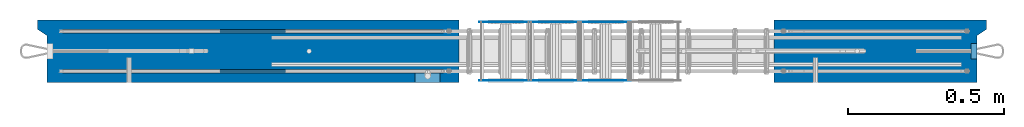
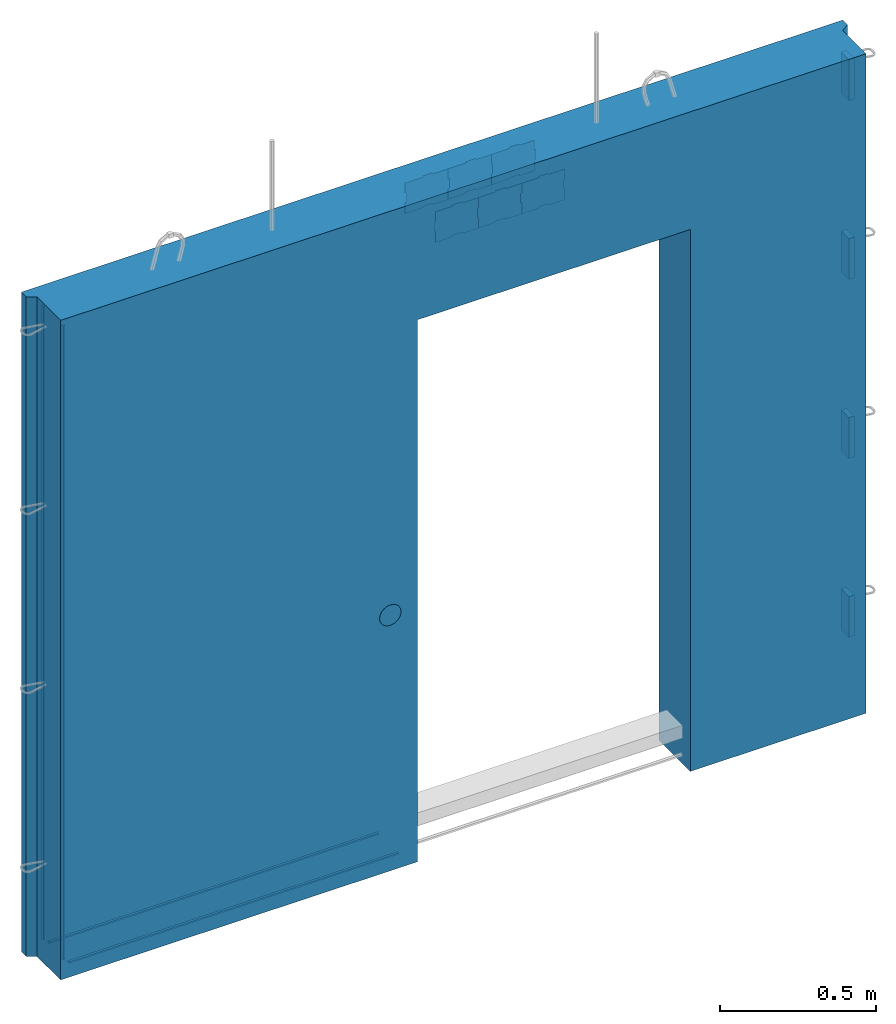
# One storey, part 6 of 11: 11 plates, 2 reinforcing bars, 1 wall.
"""IFC2X3 building model written with IfcOpenShell, lengths in millimetres."""

from ifc_helpers import new_model, si_unit, frame, origin_with_axes, place, context, subcontext, project, spatial, faceted_brep, source, transform, mapped, material, type_object, element, save


model = new_model("IFC2X3")

# Units and contexts
model_context = context("Model", 3, precision=1e-05, world=origin_with_axes())
body_context = subcontext(model_context, "Body", "Model", "MODEL_VIEW")
ifc_project = project(units=[si_unit("LENGTHUNIT", "METRE", prefix="MILLI"), si_unit("AREAUNIT", "SQUARE_METRE"), si_unit("VOLUMEUNIT", "CUBIC_METRE"), si_unit("MASSUNIT", "GRAM", prefix="KILO"), si_unit("TIMEUNIT", "SECOND"), si_unit("PLANEANGLEUNIT", "RADIAN"), si_unit("SOLIDANGLEUNIT", "STERADIAN"), si_unit("THERMODYNAMICTEMPERATUREUNIT", "DEGREE_CELSIUS"), si_unit("LUMINOUSINTENSITYUNIT", "LUMEN")], contexts=[model_context])

# Site, building, storey
site_placement = place(None, origin_with_axes())
site = spatial("IfcSite", under=ifc_project, at=site_placement, CompositionType="ELEMENT")
building_placement = place(site_placement, origin_with_axes())
building = spatial("IfcBuilding", under=site, at=building_placement, Name="Undefined", CompositionType="ELEMENT")
storey_placement = place(building_placement, origin_with_axes())
storey = spatial("IfcBuildingStorey", under=building, at=storey_placement, Name="Undefined", CompositionType="ELEMENT", Elevation=0.0)

# Plates
ifc_material_1 = material(Name="STEEL/Steel_Undefined")
plate_type_1 = type_object("IfcPlateType", PredefinedType="NOTDEFINED")
for number, where, z_axis, x_axis, name in (
    (1, (2990.01526628549, -74.9999984225414, 212.500000041022), (1.0, 0.0, 0.0), (0.0, -1.0, 0.0), "VL80"),
    (2, (2990.01526378904, -75.0000004196463, 912.500000041034), (1.0, 0.0, 0.0), (0.0, -1.0, 0.0), "VL80"),
    (3, (2990.01526378897, -75.0000004196424, 1612.50000004103), (1.0, 0.0, 0.0), (0.0, -1.0, 0.0), "VL80"),
    (4, (2990.01526378889, -75.0000004196453, 2312.50000004103), (1.0, 0.0, 0.0), (0.0, -1.0, 0.0), "VL80"),
):
    element("IfcPlate", number, at=place(storey_placement, frame(where, z_axis=z_axis, x_axis=x_axis)), inside=storey, type_object=plate_type_1, material=ifc_material_1, Name=name, context=body_context, shape_type="Brep", body=[
        faceted_brep([(-1.4210854715202e-14, -80.0, -7.105427357601e-15), (-1.4210854715202e-14, -80.0, 20.0), (-1.4210854715202e-14, 80.0, 20.0), (-1.4210854715202e-14, 80.0, -7.105427357601e-15), (50.0, -80.0, 20.0), (50.0, 80.0, 20.0), (50.0, -80.0, -7.105427357601e-15), (50.0, 80.0, -7.105427357601e-15)], [[[0, 1, 2, 3]], [[1, 4, 5, 2]], [[4, 6, 7, 5]], [[6, 0, 3, 7]], [[5, 7, 3, 2]], [[6, 4, 1, 0]]]),
    ])
plate_type_2 = type_object("IfcPlateType", PredefinedType="NOTDEFINED")
plate_1_placement = place(storey_placement, frame((1734.98457749309, -6.08317012009302, 2270.0138184004), z_axis=(0.0, 0.0, 1.0), x_axis=(-1.0, 0.0, 0.0)))
element("IfcPlate", 5, at=plate_1_placement, inside=storey, type_object=plate_type_2, material=ifc_material_1, context=body_context, shape_type="Brep", body=[
    faceted_brep([(0.0, -1.0, 0.0), (0.0, -1.0, 43.0), (0.0, 1.0, 43.0), (0.0, 1.0, 0.0), (-5.0, -1.0, 44.0), (-5.0, 1.0, 44.0), (-5.0, -1.0, 81.0), (-5.0, 1.0, 81.0), (0.0, -1.0, 82.0), (0.0, 1.0, 82.0), (0.0, -1.0, 120.0), (0.0, 1.0, 120.0), (55.5, -1.0, 120.0), (55.5, 1.0, 120.0), (56.5, -1.0, 125.0), (56.5, 1.0, 125.0), (93.5, -1.0, 125.0), (93.5, 1.0, 125.0), (94.5, -1.0, 120.0), (94.5, 1.0, 120.0), (160.0, -1.0, 120.0), (160.0, 1.0, 120.0), (160.0, -1.0, 82.0), (160.0, 1.0, 82.0), (155.0, -1.0, 81.0), (155.0, 1.0, 81.0), (155.0, -1.0, 44.0), (155.0, 1.0, 44.0), (160.0, -1.0, 43.0), (160.0, 1.0, 43.0), (160.0, -1.0, -2.72848410531878e-12), (160.0, 1.0, -2.72848410531878e-12), (94.5, -1.0, 0.0), (94.5, 1.0, 0.0), (93.5, -1.0, 5.0), (93.5, 1.0, 5.0), (56.5, -1.0, 5.0), (56.5, 1.0, 5.0), (55.5, -1.0, 0.0), (55.5, 1.0, 0.0)], [[[0, 1, 2, 3]], [[1, 4, 5, 2]], [[4, 6, 7, 5]], [[6, 8, 9, 7]], [[8, 10, 11, 9]], [[10, 12, 13, 11]], [[12, 14, 15, 13]], [[14, 16, 17, 15]], [[16, 18, 19, 17]], [[18, 20, 21, 19]], [[20, 22, 23, 21]], [[22, 24, 25, 23]], [[24, 26, 27, 25]], [[26, 28, 29, 27]], [[28, 30, 31, 29]], [[30, 32, 33, 31]], [[32, 34, 35, 33]], [[34, 36, 37, 35]], [[36, 38, 39, 37]], [[38, 0, 3, 39]], [[5, 7, 9, 11, 13, 15, 17, 19, 21, 23, 25, 27, 29, 31, 33, 35, 37, 39, 3, 2]], [[38, 36, 34, 32, 30, 28, 26, 24, 22, 20, 18, 16, 14, 12, 10, 8, 6, 4, 1, 0]]]),
])
plate_2_placement = place(storey_placement, frame((1739.98457749309, -194.083170120093, 2270.0138184004), z_axis=(0.0, 0.0, 1.0), x_axis=(-1.0, 0.0, 0.0)))
element("IfcPlate", 6, at=plate_2_placement, inside=storey, type_object=plate_type_2, material=ifc_material_1, context=body_context, shape_type="Brep", body=[
    faceted_brep([(0.0, -1.0, 0.0), (0.0, -1.0, 43.0), (0.0, 1.0, 43.0), (0.0, 1.0, 0.0), (5.0, -1.0, 44.0), (5.0, 1.0, 44.0), (5.0, -1.0, 81.0), (5.0, 1.0, 81.0), (0.0, -1.0, 82.0), (0.0, 1.0, 82.0), (0.0, -1.0, 120.0), (0.0, 1.0, 120.0), (60.5, -1.0, 120.0), (60.5, 1.0, 120.0), (61.5, -1.0, 125.0), (61.5, 1.0, 125.0), (98.5, -1.0, 125.0), (98.5, 1.0, 125.0), (99.5, -1.0, 120.0), (99.5, 1.0, 120.0), (160.0, -1.0, 120.0), (160.0, 1.0, 120.0), (160.0, -1.0, 82.0), (160.0, 1.0, 82.0), (165.0, -1.0, 81.0), (165.0, 1.0, 81.0), (165.0, -1.0, 44.0), (165.0, 1.0, 44.0), (160.0, -1.0, 43.0), (160.0, 1.0, 43.0), (160.0, -1.0, -2.72848410531878e-12), (160.0, 1.0, -2.72848410531878e-12), (99.5, -1.0, 0.0), (99.5, 1.0, 0.0), (98.5, -1.0, 5.0), (98.5, 1.0, 5.0), (61.5, -1.0, 5.0), (61.5, 1.0, 5.0), (60.5, -1.0, 0.0), (60.5, 1.0, 0.0)], [[[0, 1, 2, 3]], [[1, 4, 5, 2]], [[4, 6, 7, 5]], [[6, 8, 9, 7]], [[8, 10, 11, 9]], [[10, 12, 13, 11]], [[12, 14, 15, 13]], [[14, 16, 17, 15]], [[16, 18, 19, 17]], [[18, 20, 21, 19]], [[20, 22, 23, 21]], [[22, 24, 25, 23]], [[24, 26, 27, 25]], [[26, 28, 29, 27]], [[28, 30, 31, 29]], [[30, 32, 33, 31]], [[32, 34, 35, 33]], [[34, 36, 37, 35]], [[36, 38, 39, 37]], [[38, 0, 3, 39]], [[5, 7, 9, 11, 13, 15, 17, 19, 21, 23, 25, 27, 29, 31, 33, 35, 37, 39, 3, 2]], [[38, 36, 34, 32, 30, 28, 26, 24, 22, 20, 18, 16, 14, 12, 10, 8, 6, 4, 1, 0]]]),
])
plate_3_placement = place(storey_placement, frame((1894.98457749309, -6.08317012009296, 2270.0138184004), z_axis=(0.0, 0.0, 1.0), x_axis=(-1.0, 0.0, 0.0)))
element("IfcPlate", 7, at=plate_3_placement, inside=storey, type_object=plate_type_2, material=ifc_material_1, context=body_context, shape_type="Brep", body=[
    faceted_brep([(0.0, -1.0, 0.0), (0.0, -1.0, 43.0), (0.0, 1.0, 43.0), (0.0, 1.0, 0.0), (-5.0, -1.0, 44.0), (-5.0, 1.0, 44.0), (-5.0, -1.0, 81.0), (-5.0, 1.0, 81.0), (0.0, -1.0, 82.0), (0.0, 1.0, 82.0), (0.0, -1.0, 120.0), (0.0, 1.0, 120.0), (55.5, -1.0, 120.0), (55.5, 1.0, 120.0), (56.5, -1.0, 125.0), (56.5, 1.0, 125.0), (93.5, -1.0, 125.0), (93.5, 1.0, 125.0), (94.5, -1.0, 120.0), (94.5, 1.0, 120.0), (160.0, -1.0, 120.0), (160.0, 1.0, 120.0), (160.0, -1.0, 82.0), (160.0, 1.0, 82.0), (155.0, -1.0, 81.0), (155.0, 1.0, 81.0), (155.0, -1.0, 44.0), (155.0, 1.0, 44.0), (160.0, -1.0, 43.0), (160.0, 1.0, 43.0), (160.0, -1.0, -2.72848410531878e-12), (160.0, 1.0, -2.72848410531878e-12), (94.5, -1.0, 0.0), (94.5, 1.0, 0.0), (93.5, -1.0, 5.0), (93.5, 1.0, 5.0), (56.5, -1.0, 5.0), (56.5, 1.0, 5.0), (55.5, -1.0, 0.0), (55.5, 1.0, 0.0)], [[[0, 1, 2, 3]], [[1, 4, 5, 2]], [[4, 6, 7, 5]], [[6, 8, 9, 7]], [[8, 10, 11, 9]], [[10, 12, 13, 11]], [[12, 14, 15, 13]], [[14, 16, 17, 15]], [[16, 18, 19, 17]], [[18, 20, 21, 19]], [[20, 22, 23, 21]], [[22, 24, 25, 23]], [[24, 26, 27, 25]], [[26, 28, 29, 27]], [[28, 30, 31, 29]], [[30, 32, 33, 31]], [[32, 34, 35, 33]], [[34, 36, 37, 35]], [[36, 38, 39, 37]], [[38, 0, 3, 39]], [[5, 7, 9, 11, 13, 15, 17, 19, 21, 23, 25, 27, 29, 31, 33, 35, 37, 39, 3, 2]], [[38, 36, 34, 32, 30, 28, 26, 24, 22, 20, 18, 16, 14, 12, 10, 8, 6, 4, 1, 0]]]),
])
plate_4_placement = place(storey_placement, frame((1899.98457749309, -194.083170120093, 2270.0138184004), z_axis=(0.0, 0.0, 1.0), x_axis=(-1.0, 0.0, 0.0)))
element("IfcPlate", 8, at=plate_4_placement, inside=storey, type_object=plate_type_2, material=ifc_material_1, context=body_context, shape_type="Brep", body=[
    faceted_brep([(0.0, -1.0, 0.0), (0.0, -1.0, 43.0), (0.0, 1.0, 43.0), (0.0, 1.0, 0.0), (5.0, -1.0, 44.0), (5.0, 1.0, 44.0), (5.0, -1.0, 81.0), (5.0, 1.0, 81.0), (0.0, -1.0, 82.0), (0.0, 1.0, 82.0), (0.0, -1.0, 120.0), (0.0, 1.0, 120.0), (60.5, -1.0, 120.0), (60.5, 1.0, 120.0), (61.5, -1.0, 125.0), (61.5, 1.0, 125.0), (98.5, -1.0, 125.0), (98.5, 1.0, 125.0), (99.5, -1.0, 120.0), (99.5, 1.0, 120.0), (160.0, -1.0, 120.0), (160.0, 1.0, 120.0), (160.0, -1.0, 82.0), (160.0, 1.0, 82.0), (165.0, -1.0, 81.0), (165.0, 1.0, 81.0), (165.0, -1.0, 44.0), (165.0, 1.0, 44.0), (160.0, -1.0, 43.0), (160.0, 1.0, 43.0), (160.0, -1.0, -2.72848410531878e-12), (160.0, 1.0, -2.72848410531878e-12), (99.5, -1.0, 0.0), (99.5, 1.0, 0.0), (98.5, -1.0, 5.0), (98.5, 1.0, 5.0), (61.5, -1.0, 5.0), (61.5, 1.0, 5.0), (60.5, -1.0, 0.0), (60.5, 1.0, 0.0)], [[[0, 1, 2, 3]], [[1, 4, 5, 2]], [[4, 6, 7, 5]], [[6, 8, 9, 7]], [[8, 10, 11, 9]], [[10, 12, 13, 11]], [[12, 14, 15, 13]], [[14, 16, 17, 15]], [[16, 18, 19, 17]], [[18, 20, 21, 19]], [[20, 22, 23, 21]], [[22, 24, 25, 23]], [[24, 26, 27, 25]], [[26, 28, 29, 27]], [[28, 30, 31, 29]], [[30, 32, 33, 31]], [[32, 34, 35, 33]], [[34, 36, 37, 35]], [[36, 38, 39, 37]], [[38, 0, 3, 39]], [[5, 7, 9, 11, 13, 15, 17, 19, 21, 23, 25, 27, 29, 31, 33, 35, 37, 39, 3, 2]], [[38, 36, 34, 32, 30, 28, 26, 24, 22, 20, 18, 16, 14, 12, 10, 8, 6, 4, 1, 0]]]),
])
plate_5_placement = place(storey_placement, frame((1574.98457749309, -6.08317012009302, 2270.0138184004), z_axis=(0.0, 0.0, 1.0), x_axis=(-1.0, 0.0, 0.0)))
element("IfcPlate", 9, at=plate_5_placement, inside=storey, type_object=plate_type_2, material=ifc_material_1, context=body_context, shape_type="Brep", body=[
    faceted_brep([(0.0, -1.0, 0.0), (0.0, -1.0, 43.0), (0.0, 1.0, 43.0), (0.0, 1.0, 0.0), (-5.0, -1.0, 44.0), (-5.0, 1.0, 44.0), (-5.0, -1.0, 81.0), (-5.0, 1.0, 81.0), (0.0, -1.0, 82.0), (0.0, 1.0, 82.0), (0.0, -1.0, 120.0), (0.0, 1.0, 120.0), (55.5, -1.0, 120.0), (55.5, 1.0, 120.0), (56.5, -1.0, 125.0), (56.5, 1.0, 125.0), (93.5, -1.0, 125.0), (93.5, 1.0, 125.0), (94.5, -1.0, 120.0), (94.5, 1.0, 120.0), (160.0, -1.0, 120.0), (160.0, 1.0, 120.0), (160.0, -1.0, 82.0), (160.0, 1.0, 82.0), (155.0, -1.0, 81.0), (155.0, 1.0, 81.0), (155.0, -1.0, 44.0), (155.0, 1.0, 44.0), (160.0, -1.0, 43.0), (160.0, 1.0, 43.0), (160.0, -1.0, -2.72848410531878e-12), (160.0, 1.0, -2.72848410531878e-12), (94.5, -1.0, 0.0), (94.5, 1.0, 0.0), (93.5, -1.0, 5.0), (93.5, 1.0, 5.0), (56.5, -1.0, 5.0), (56.5, 1.0, 5.0), (55.5, -1.0, 0.0), (55.5, 1.0, 0.0)], [[[0, 1, 2, 3]], [[1, 4, 5, 2]], [[4, 6, 7, 5]], [[6, 8, 9, 7]], [[8, 10, 11, 9]], [[10, 12, 13, 11]], [[12, 14, 15, 13]], [[14, 16, 17, 15]], [[16, 18, 19, 17]], [[18, 20, 21, 19]], [[20, 22, 23, 21]], [[22, 24, 25, 23]], [[24, 26, 27, 25]], [[26, 28, 29, 27]], [[28, 30, 31, 29]], [[30, 32, 33, 31]], [[32, 34, 35, 33]], [[34, 36, 37, 35]], [[36, 38, 39, 37]], [[38, 0, 3, 39]], [[5, 7, 9, 11, 13, 15, 17, 19, 21, 23, 25, 27, 29, 31, 33, 35, 37, 39, 3, 2]], [[38, 36, 34, 32, 30, 28, 26, 24, 22, 20, 18, 16, 14, 12, 10, 8, 6, 4, 1, 0]]]),
])
plate_6_placement = place(storey_placement, frame((1579.98457749309, -194.083170120093, 2270.0138184004), z_axis=(0.0, 0.0, 1.0), x_axis=(-1.0, 0.0, 0.0)))
element("IfcPlate", 10, at=plate_6_placement, inside=storey, type_object=plate_type_2, material=ifc_material_1, context=body_context, shape_type="Brep", body=[
    faceted_brep([(0.0, -1.0, 0.0), (0.0, -1.0, 43.0), (0.0, 1.0, 43.0), (0.0, 1.0, 0.0), (5.0, -1.0, 44.0), (5.0, 1.0, 44.0), (5.0, -1.0, 81.0), (5.0, 1.0, 81.0), (0.0, -1.0, 82.0), (0.0, 1.0, 82.0), (0.0, -1.0, 120.0), (0.0, 1.0, 120.0), (60.5, -1.0, 120.0), (60.5, 1.0, 120.0), (61.5, -1.0, 125.0), (61.5, 1.0, 125.0), (98.5, -1.0, 125.0), (98.5, 1.0, 125.0), (99.5, -1.0, 120.0), (99.5, 1.0, 120.0), (160.0, -1.0, 120.0), (160.0, 1.0, 120.0), (160.0, -1.0, 82.0), (160.0, 1.0, 82.0), (165.0, -1.0, 81.0), (165.0, 1.0, 81.0), (165.0, -1.0, 44.0), (165.0, 1.0, 44.0), (160.0, -1.0, 43.0), (160.0, 1.0, 43.0), (160.0, -1.0, -2.72848410531878e-12), (160.0, 1.0, -2.72848410531878e-12), (99.5, -1.0, 0.0), (99.5, 1.0, 0.0), (98.5, -1.0, 5.0), (98.5, 1.0, 5.0), (61.5, -1.0, 5.0), (61.5, 1.0, 5.0), (60.5, -1.0, 0.0), (60.5, 1.0, 0.0)], [[[0, 1, 2, 3]], [[1, 4, 5, 2]], [[4, 6, 7, 5]], [[6, 8, 9, 7]], [[8, 10, 11, 9]], [[10, 12, 13, 11]], [[12, 14, 15, 13]], [[14, 16, 17, 15]], [[16, 18, 19, 17]], [[18, 20, 21, 19]], [[20, 22, 23, 21]], [[22, 24, 25, 23]], [[24, 26, 27, 25]], [[26, 28, 29, 27]], [[28, 30, 31, 29]], [[30, 32, 33, 31]], [[32, 34, 35, 33]], [[34, 36, 37, 35]], [[36, 38, 39, 37]], [[38, 0, 3, 39]], [[5, 7, 9, 11, 13, 15, 17, 19, 21, 23, 25, 27, 29, 31, 33, 35, 37, 39, 3, 2]], [[38, 36, 34, 32, 30, 28, 26, 24, 22, 20, 18, 16, 14, 12, 10, 8, 6, 4, 1, 0]]]),
])
ifc_material_2 = material()
plate_type_3 = type_object("IfcPlateType", PredefinedType="NOTDEFINED")
plate_7_placement = place(storey_placement, frame((1289.99888029706, -184.999999419566, 835.00173393611), z_axis=(0.0, 0.0, 1.0), x_axis=(-1.0, 0.0, 0.0)))
element("IfcPlate", 11, at=plate_7_placement, inside=storey, type_object=plate_type_3, material=ifc_material_2, Name="K", context=body_context, shape_type="Brep", body=[
    faceted_brep([(40.0, -25.0, 80.0), (47.0710678118655, -22.0710678118655, 80.0), (47.0710678118655, -22.0710678118655, 100.0), (40.0, -25.0, 100.0), (32.9289321881345, -22.0710678118655, 80.0), (32.9289321881345, -22.0710678118655, 100.0), (30.0, -15.0, 80.0), (30.0, -15.0, 100.0), (32.9289321881345, -7.92893218813452, 80.0), (32.9289321881345, -7.92893218813452, 100.0), (40.0, -5.0, 80.0), (40.0, -5.0, 100.0), (47.0710678118655, -7.92893218813452, 80.0), (47.0710678118655, -7.92893218813452, 100.0), (50.0, -15.0, 80.0), (50.0, -15.0, 100.0), (7.63932022500217, -15.0, 16.488589908301), (1.95773934819385, -15.0, 27.6393202250021), (1.95773934819385, 15.0, 27.6393202250021), (7.63932022500217, 15.0, 16.488589908301), (16.488589908301, -15.0, 7.63932022500205), (16.488589908301, 15.0, 7.63932022500205), (27.6393202250022, -15.0, 1.95773934819385), (27.6393202250022, 15.0, 1.95773934819385), (40.0, -15.0, 0.0), (40.0, 15.0, 0.0), (52.3606797749978, -15.0, 1.95773934819385), (52.3606797749978, 15.0, 1.95773934819385), (63.511410091699, -15.0, 7.63932022500217), (63.511410091699, 15.0, 7.63932022500217), (72.3606797749978, -15.0, 16.488589908301), (72.3606797749978, 15.0, 16.488589908301), (78.0422606518061, -15.0, 27.6393202250022), (78.0422606518061, 15.0, 27.6393202250022), (80.0, -15.0, 40.0), (80.0, 15.0, 40.0), (78.0422606518061, -15.0, 52.3606797749978), (78.0422606518061, 15.0, 52.3606797749978), (72.3606797749978, -15.0, 63.511410091699), (72.3606797749978, 15.0, 63.511410091699), (63.511410091699, -15.0, 72.3606797749978), (63.511410091699, 15.0, 72.3606797749978), (52.3606797749978, -15.0, 78.0422606518061), (52.3606797749978, 15.0, 78.0422606518061), (40.0, -15.0, 80.0), (40.0, 15.0, 80.0), (27.6393202250022, -15.0, 78.0422606518061), (27.6393202250022, 15.0, 78.0422606518061), (16.488589908301, -15.0, 72.3606797749978), (16.488589908301, 15.0, 72.3606797749978), (7.63932022500217, -15.0, 63.511410091699), (7.63932022500217, 15.0, 63.511410091699), (1.95773934819385, -15.0, 52.3606797749978), (1.95773934819385, 15.0, 52.3606797749978), (0.0, -15.0, 40.0), (0.0, 15.0, 40.0)], [[[0, 1, 2, 3]], [[4, 0, 3, 5]], [[6, 4, 5, 7]], [[8, 6, 7, 9]], [[10, 8, 9, 11]], [[12, 10, 11, 13]], [[1, 0, 4, 6, 8, 10, 12, 14]], [[1, 14, 15, 2]], [[11, 9, 7, 5, 3, 2, 15, 13]], [[14, 12, 13, 15]], [[16, 17, 18, 19]], [[20, 16, 19, 21]], [[22, 20, 21, 23]], [[24, 22, 23, 25]], [[26, 24, 25, 27]], [[28, 26, 27, 29]], [[30, 28, 29, 31]], [[32, 30, 31, 33]], [[34, 32, 33, 35]], [[36, 34, 35, 37]], [[38, 36, 37, 39]], [[40, 38, 39, 41]], [[42, 40, 41, 43]], [[44, 42, 43, 45]], [[46, 44, 45, 47]], [[48, 46, 47, 49]], [[50, 48, 49, 51]], [[52, 50, 51, 53]], [[17, 16, 20, 22, 24, 26, 28, 30, 32, 34, 36, 38, 40, 42, 44, 46, 48, 50, 52, 54]], [[17, 54, 55, 18]], [[51, 49, 47, 45, 43, 41, 39, 37, 35, 33, 31, 29, 27, 25, 23, 21, 19, 18, 55, 53]], [[54, 52, 53, 55]]]),
])

# Wall
ifc_material_3 = material(Name="CONCRETE/C25/30")
wall_type = type_object("IfcWallType", PredefinedType="NOTDEFINED")
wall_placement = place(storey_placement, frame((1.45394807304911e-11, -99.9999994195659, 1165.00000004103), z_axis=(0.0, 0.0, 1.0), x_axis=(1.0, 0.0, 0.0)))
element("IfcWall", 12, at=wall_placement, inside=storey, type_object=wall_type, material=ifc_material_3, context=body_context, shape_type="Brep", body=[
    faceted_brep([(1349.99888029705, 100.0, 830.00173389508), (1349.99888029705, -100.0, 830.00173389508), (1349.99888029705, -100.0, -1290.0), (1349.99888029705, 100.0, -1290.0), (2360.00091552729, 100.0, 830.00173389508), (2360.00091552729, -100.0, 830.00173389508), (2360.00091552729, 100.0, -1290.0), (2360.00091552729, -100.0, -1290.0), (3040.01525878906, 100.0, -1290.0), (3040.01525878906, 100.0, 1290.0), (3040.01525878909, 70.000000000009, 1290.0), (3040.01525878906, 70.000000000009, -1290.0), (3010.01524147726, -100.0, 1290.0), (3010.01524147726, -100.0, -1290.0), (3010.01525819004, 50.0000032061919, -1290.0), (3010.01525819004, 50.0000032061919, 1290.0), (0.0, 100.0, 1290.0), (0.0, 70.0000000000144, 1290.0), (30.0000000000145, 50.0000000000144, 1290.00000000001), (30.0000000000146, -100.0, 1290.0), (30.0000000000145, 50.0000000000144, -1289.99999999999), (30.0000000000146, -100.0, -1290.0), (0.0, 70.0000000000144, -1290.0), (0.0, 100.0, -1290.0)], [[[0, 1, 2, 3]], [[4, 5, 1, 0]], [[6, 7, 5, 4]], [[8, 9, 10, 11]], [[12, 13, 14, 15]], [[10, 15, 14, 11]], [[9, 16, 17, 18, 19, 12, 15, 10]], [[18, 20, 21, 19]], [[17, 22, 20, 18]], [[16, 23, 22, 17]], [[21, 20, 22, 23, 3, 2]], [[13, 12, 19, 21, 2, 1, 5, 7]], [[8, 11, 14, 13, 7, 6]], [[3, 23, 16, 9, 8, 6, 4, 0]]]),
])

# Reinforcing bars
ifc_material_4 = material(Name="A500HW")
shared_shape_1 = source(origin_with_axes(), body_context, "Body", "Brep", [
    faceted_brep([(0.0, 5.19615242270663, 3.0), (0.0, 5.19615242270663, -3.0), (0.0, -2.33146835171283e-15, -6.0), (0.0, -5.19615242270663, -3.0), (0.0, -5.19615242270663, 3.0), (0.0, 0.0, 6.0), (2480.0, -5.19615242270663, 3.0), (2480.0, 0.0, 6.0), (2480.0, -5.19615242270663, -3.0), (2480.0, -2.33146835171283e-15, -6.0), (2480.0, 5.19615242270663, -3.0), (2480.0, 5.19615242270663, 3.0)], [[[0, 1, 2, 3, 4, 5]], [[5, 4, 6, 7]], [[4, 3, 8, 6]], [[3, 2, 9, 8]], [[2, 1, 10, 9]], [[1, 0, 11, 10]], [[0, 5, 7, 11]], [[7, 6, 8, 9, 10, 11]]]),
])
shared_shape_2 = source(origin_with_axes(), body_context, "Body", "Brep", [
    faceted_brep([(0.0, 5.19615242270663, 3.0), (0.0, 5.19615242270663, -3.0), (0.0, -2.33146835171283e-15, -6.0), (0.0, -5.19615242270663, -3.0), (0.0, -5.19615242270663, 3.0), (0.0, 0.0, 6.0), (2480.0, -5.19615242270663, 3.0), (2480.0, 0.0, 6.0), (2480.0, -5.19615242270663, -3.0), (2480.0, -2.33146835171283e-15, -6.0), (2480.0, 5.19615242270663, -3.0), (2480.0, 5.19615242270663, 3.0)], [[[0, 1, 2, 3, 4, 5]], [[5, 4, 6, 7]], [[4, 3, 8, 6]], [[3, 2, 9, 8]], [[2, 1, 10, 9]], [[1, 0, 11, 10]], [[0, 5, 7, 11]], [[7, 6, 8, 9, 10, 11]]]),
])
reinforcing_bar_1_placement = place(storey_placement, frame((30.0, -200.0, 2455.0), z_axis=(1.0, 0.0, 0.0), x_axis=(0.0, 0.0, -1.0)))
element("IfcReinforcingBar", 13, at=reinforcing_bar_1_placement, inside=storey, material=ifc_material_4, Name="sk", BarRole="NOTDEFINED", CrossSectionArea=0.0, NominalDiameter=12.0, context=body_context, shape_type="MappedRepresentation", body=[
    mapped(shared_shape_1, transform((50.0, 36.0, 31.0))),
    mapped(shared_shape_2, transform((50.0, 164.00000058042, 31.0))),
])
shared_shape_3 = source(origin_with_axes(), body_context, "Body", "Brep", [
    faceted_brep([(0.0, 5.19615242270663, 3.0), (0.0, 5.19615242270663, -3.0), (0.0, -2.33146835171283e-15, -6.0), (0.0, -5.19615242270663, -3.0), (0.0, -5.19615242270663, 3.0), (0.0, 0.0, 6.0), (1219.9989, -5.19615242270663, 3.0), (1219.9989, 0.0, 6.0), (1219.9989, -5.19615242270663, -3.0), (1219.9989, -2.33146835171283e-15, -6.0), (1219.9989, 5.19615242270663, -3.0), (1219.9989, 5.19615242270663, 3.0)], [[[0, 1, 2, 3, 4, 5]], [[5, 4, 6, 7]], [[4, 3, 8, 6]], [[3, 2, 9, 8]], [[2, 1, 10, 9]], [[1, 0, 11, 10]], [[0, 5, 7, 11]], [[7, 6, 8, 9, 10, 11]]]),
])
shared_shape_4 = source(origin_with_axes(), body_context, "Body", "Brep", [
    faceted_brep([(0.0, 5.19615242270663, 3.0), (0.0, 5.19615242270663, -3.0), (0.0, -2.33146835171283e-15, -6.0), (0.0, -5.19615242270663, -3.0), (0.0, -5.19615242270663, 3.0), (0.0, 0.0, 6.0), (1219.9989, -5.19615242270663, 3.0), (1219.9989, 0.0, 6.0), (1219.9989, -5.19615242270663, -3.0), (1219.9989, -2.33146835171283e-15, -6.0), (1219.9989, 5.19615242270663, -3.0), (1219.9989, 5.19615242270663, 3.0)], [[[0, 1, 2, 3, 4, 5]], [[5, 4, 6, 7]], [[4, 3, 8, 6]], [[3, 2, 9, 8]], [[2, 1, 10, 9]], [[1, 0, 11, 10]], [[0, 5, 7, 11]], [[7, 6, 8, 9, 10, 11]]]),
])
reinforcing_bar_2_placement = place(storey_placement, frame((30.0, -200.0, -125.0), z_axis=(0.0, 0.0, 1.0), x_axis=(1.0, 0.0, 0.0)))
element("IfcReinforcingBar", 14, at=reinforcing_bar_2_placement, inside=storey, material=ifc_material_4, Name="sk", BarRole="NOTDEFINED", CrossSectionArea=0.0, NominalDiameter=12.0, context=body_context, shape_type="MappedRepresentation", body=[
    mapped(shared_shape_3, transform((50.0, 36.0, 31.0))),
    mapped(shared_shape_4, transform((50.0, 164.00000058042, 31.0))),
])

save(model, "model.ifc")
